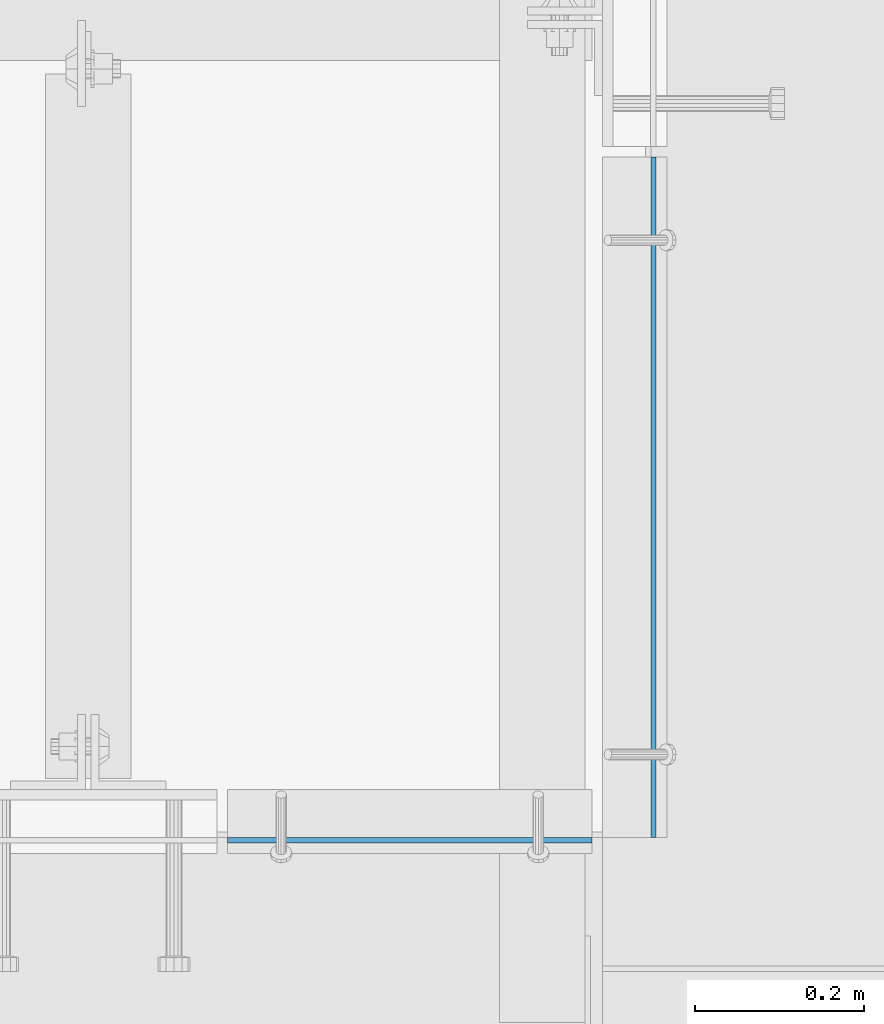
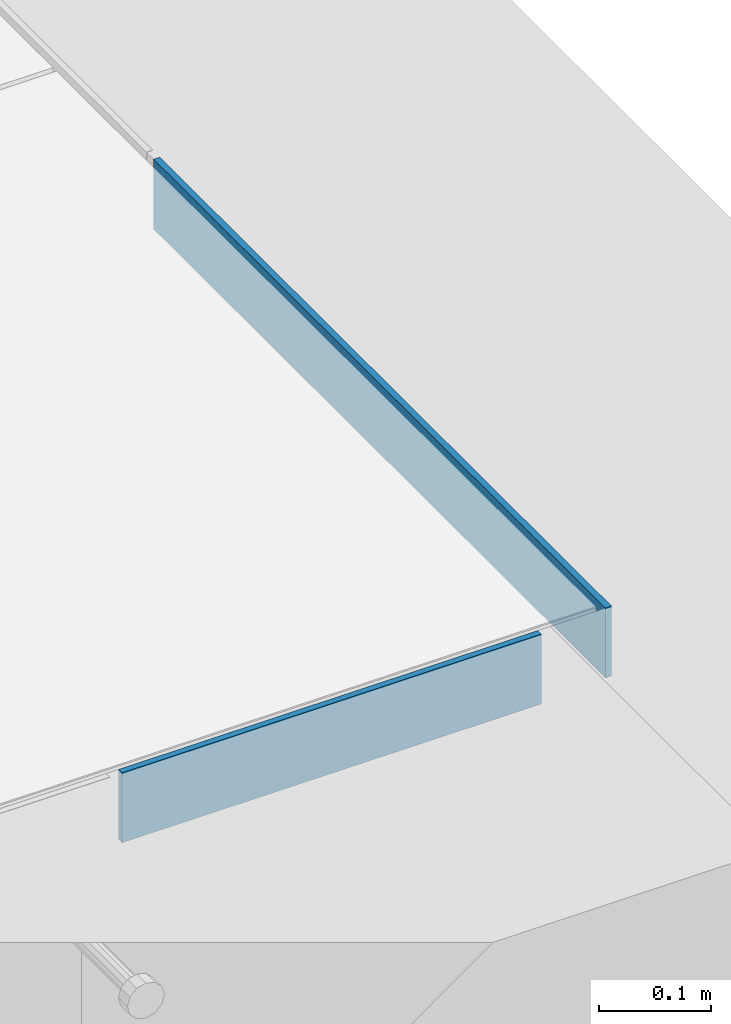
# One storey, part 3052 of 3843: 2 plates, 2 elements without a shape of their own.
"""IFC2X3 building model written with IfcOpenShell, lengths in millimetres."""

from ifc_helpers import new_model, si_unit, frame, origin_with_axes, place, context, subcontext, project, spatial, faceted_brep, material, type_object, element, aggregate, save


model = new_model("IFC2X3")

# Units and contexts
model_context = context("Model", 3, precision=1e-05, world=origin_with_axes())
body_context = subcontext(model_context, "Body", "Model", "MODEL_VIEW")
ifc_project = project(units=[si_unit("LENGTHUNIT", "METRE", prefix="MILLI"), si_unit("AREAUNIT", "SQUARE_METRE"), si_unit("VOLUMEUNIT", "CUBIC_METRE"), si_unit("MASSUNIT", "GRAM", prefix="KILO"), si_unit("TIMEUNIT", "SECOND"), si_unit("PLANEANGLEUNIT", "RADIAN"), si_unit("SOLIDANGLEUNIT", "STERADIAN"), si_unit("THERMODYNAMICTEMPERATUREUNIT", "DEGREE_CELSIUS"), si_unit("LUMINOUSINTENSITYUNIT", "LUMEN")], contexts=[model_context])

# Site, building, storey
site_placement = place(None, origin_with_axes())
site = spatial("IfcSite", under=ifc_project, at=site_placement, CompositionType="ELEMENT")
building_placement = place(site_placement, origin_with_axes())
building = spatial("IfcBuilding", under=site, at=building_placement, Name="Undefined", CompositionType="ELEMENT")
storey_placement = place(building_placement, origin_with_axes())
storey = spatial("IfcBuildingStorey", under=building, at=storey_placement, Name="Undefined", CompositionType="ELEMENT", Elevation=0.0)

# Assembly, plate
assembly_1_placement = place(storey_placement, origin_with_axes())
assembly_1 = element("IfcElementAssembly", 1, at=assembly_1_placement, inside=storey, Name="ANGLE", AssemblyPlace="NOTDEFINED", PredefinedType="RIGID_FRAME")
ifc_material = material(Name="STEEL/A36")
plate_type = type_object("IfcPlateType", PredefinedType="NOTDEFINED")
plate_1_placement = place(assembly_1_placement, frame((50441.2249904681, 15243.174555532, 30403.8000030518), z_axis=(0.99999999999915, 1.30400000489317e-06, 0.0), x_axis=(0.0, 0.0, 1.0)))
plate_1 = element("IfcPlate", 2, at=plate_1_placement, type_object=plate_type, material=ifc_material, Name="PLATE", context=body_context, shape_type="Brep", body=[
    faceted_brep([(0.0, -3.17499999999927, 0.0), (-1.03997081168927e-05, -3.17499999999927, 431.799987792969), (-1.03997081168927e-05, 3.17499999999927, 431.799987792969), (0.0, 3.17499999999927, 0.0), (76.1999893189823, -3.17499999999927, 431.799987793223), (76.1999893189823, 3.17499999999927, 431.799987793223), (76.1999999999971, -3.17499999999927, 0.0), (76.1999999999971, 3.17499999999927, 0.0)], [[[0, 1, 2, 3]], [[1, 4, 5, 2]], [[4, 6, 7, 5]], [[6, 0, 3, 7]], [[5, 7, 3, 2]], [[6, 4, 1, 0]]]),
])
aggregate(assembly_1, [plate_1])

assembly_2_placement = place(storey_placement, origin_with_axes())
assembly_2 = element("IfcElementAssembly", 3, at=assembly_2_placement, inside=storey, Name="ANGLE", AssemblyPlace="NOTDEFINED", PredefinedType="RIGID_FRAME")
plate_2_placement = place(assembly_2_placement, frame((50946.0499998585, 15246.3499496257, 30403.8000030518), z_axis=(0.0, 0.999999999997942, -2.02899998962774e-06), x_axis=(0.0, 2.02899999567308e-06, 0.999999999997942)))
plate_2 = element("IfcPlate", 4, at=plate_2_placement, type_object=plate_type, material=ifc_material, Name="PLATE", context=body_context, shape_type="Brep", body=[
    faceted_brep([(0.0, -3.17499999999927, 0.0), (0.00108199702663114, -3.17500000000291, 806.450036627399), (0.00108199702663114, 3.17500000000291, 806.450036627399), (0.0, 3.17499999999927, 0.0), (76.2010812158915, -3.17500000000291, 806.449975592201), (76.2010812158915, 3.17500000000291, 806.449975592201), (76.1999999999971, -3.17499999999927, 0.0), (76.1999999999971, 3.17499999999927, 0.0)], [[[0, 1, 2, 3]], [[1, 4, 5, 2]], [[4, 6, 7, 5]], [[6, 0, 3, 7]], [[5, 7, 3, 2]], [[6, 4, 1, 0]]]),
])
aggregate(assembly_2, [plate_2])

save(model, "model.ifc")
